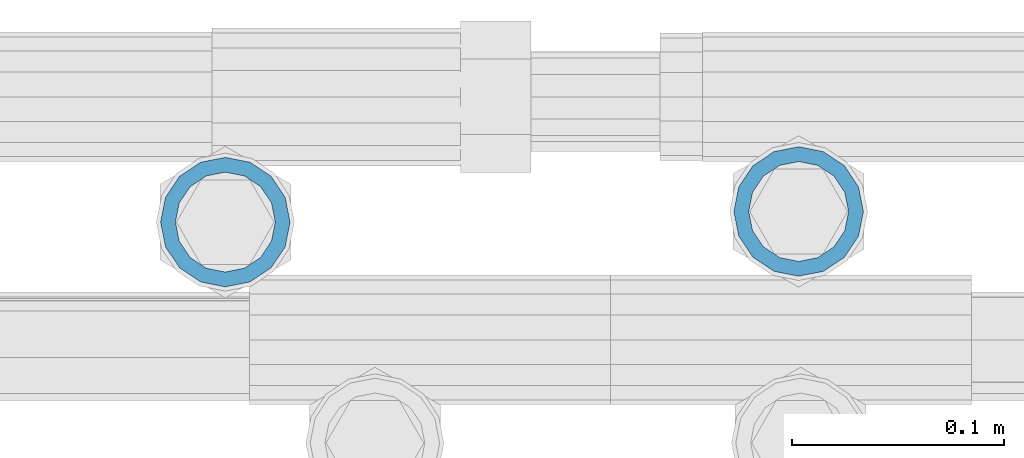
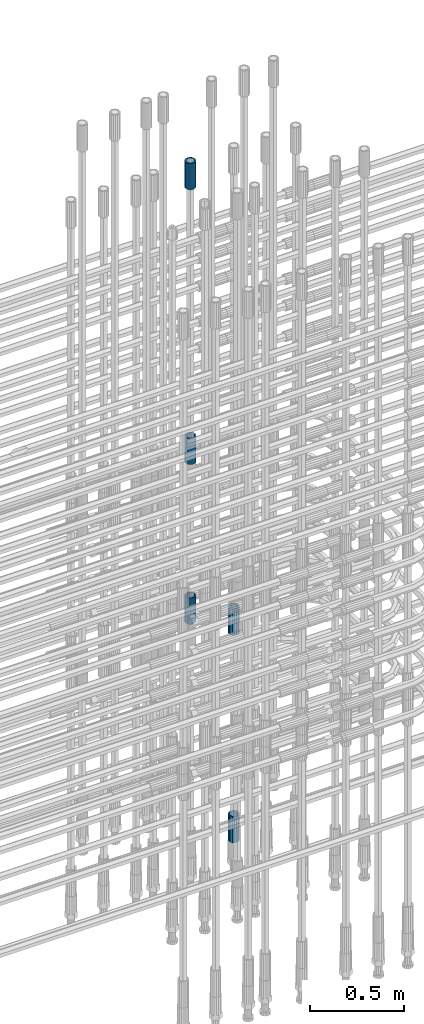
# One storey, part 75 of 119: 5 beams.
"""IFC2X3 building model written with IfcOpenShell, lengths in millimetres."""

from ifc_helpers import new_model, si_unit, frame, origin_with_axes, place, context, subcontext, project, spatial, faceted_brep, material, type_object, element, save


model = new_model("IFC2X3")

# Units and contexts
model_context = context("Model", 3, precision=1e-05, world=origin_with_axes())
body_context = subcontext(model_context, "Body", "Model", "MODEL_VIEW")
ifc_project = project(units=[si_unit("LENGTHUNIT", "METRE", prefix="MILLI"), si_unit("AREAUNIT", "SQUARE_METRE"), si_unit("VOLUMEUNIT", "CUBIC_METRE"), si_unit("MASSUNIT", "GRAM", prefix="KILO"), si_unit("TIMEUNIT", "SECOND"), si_unit("PLANEANGLEUNIT", "RADIAN"), si_unit("SOLIDANGLEUNIT", "STERADIAN"), si_unit("THERMODYNAMICTEMPERATUREUNIT", "DEGREE_CELSIUS"), si_unit("LUMINOUSINTENSITYUNIT", "LUMEN")], contexts=[model_context])

# Site, building, storey
site_placement = place(None, origin_with_axes())
site = spatial("IfcSite", under=ifc_project, at=site_placement, CompositionType="ELEMENT")
building_placement = place(site_placement, origin_with_axes())
building = spatial("IfcBuilding", under=site, at=building_placement, Name="Undefined", CompositionType="ELEMENT")
storey_placement = place(building_placement, origin_with_axes())
storey = spatial("IfcBuildingStorey", under=building, at=storey_placement, Name="Undefined", CompositionType="ELEMENT", Elevation=0.0)

# Beams
ifc_material = material(Name="STEEL/S275")
beam_type = type_object("IfcBeamType", PredefinedType="NOTDEFINED")
beam_1_placement = place(storey_placement, frame((2035854.99840131, 6206340.98567718, 20007.7168583146), z_axis=(-0.99999999999998, 1.98000110685822e-07, 0.0), x_axis=(0.0, 0.0, -1.0)))
element("IfcBeam", 1, at=beam_1_placement, inside=storey, type_object=beam_type, material=ifc_material, Name="AG40N", context=body_context, shape_type="Brep", body=[
    faceted_brep([(1.62981450557709e-09, -23.4999999990687, 0.0), (7.45058059692383e-09, -21.7111690142192, 8.99306066057534), (170.000002125278, -21.711168999318, 8.99306066022245), (170.000002127141, -23.4999999844003, -3.66071617463604e-10), (4.65661287307739e-09, -16.6170093587134, 16.6170093578889), (170.000002122484, -16.6170093440451, 16.6170093575288), (1.86264514923096e-09, -8.99306066217832, 21.7111690140277), (170.000002118759, -8.99306064750999, 21.7111690136603), (2.3283064365387e-10, 9.31322574615479e-10, 23.5), (170.000002114102, 1.28056854009628e-08, 23.4999999996485), (-6.51925802230835e-09, 8.99306065868586, 21.7111690140241), (170.00000211224, 8.99306067335419, 21.7111690136639), (-7.45058059692383e-09, 16.6170093561523, 16.6170093578853), (170.000002109446, 16.6170093708206, 16.6170093575324), (-9.31322574615479e-09, 21.711169013055, 8.99306066057534), (170.000002108514, 21.7111690277234, 8.99306066022245), (-1.16415321826935e-09, 23.5000000009313, 0.0), (170.000002108514, 23.5000000144355, -3.66071617463604e-10), (-8.38190317153931e-09, 21.7111690151505, -8.99306066059444), (170.000002110377, 21.7111690300517, -8.9930606609546), (-5.58793544769287e-09, 16.6170093598776, -16.6170093579008), (170.000002113171, 16.6170093745459, -16.6170093582609), (-9.31322574615479e-10, 8.99306066334248, -21.7111690140396), (170.000002115965, 8.99306067801081, -21.7111690143961), (2.3283064365387e-10, 9.31322574615479e-10, -23.5), (170.00000211969, 1.7927959561348e-08, -23.5000000003843), (5.58793544769287e-09, -8.99306065752171, -21.7111690140396), (170.000002123415, -8.99306064285338, -21.7111690143961), (8.38190317153931e-09, -16.6170093549881, -16.6170093579008), (170.000002125278, -16.6170093403198, -16.6170093582646), (9.31322574615479e-09, -21.7111690121237, -8.99306066059444), (170.000002127141, -21.7111689972226, -8.9930606609546), (1.11758708953857e-08, -30.4999999990687, -9.54969436861575e-12), (1.30385160446167e-08, -28.1783257392235, -11.6718446871514), (170.000002129003, -28.1783257243223, -11.6718446875116), (170.000002129935, -30.4999999841675, -3.66071617463604e-10), (1.02445483207703e-08, -21.5667568228673, -21.5667568262129), (170.000002128072, -21.566756808199, -21.5667568265694), (7.45058059692383e-09, -11.6718446831219, -28.1783257416196), (170.000002125278, -11.6718446684536, -28.1783257419834), (3.72529029846191e-09, 3.95812094211578e-09, -30.5000000000277), (170.00000211969, 1.83936208486557e-08, -30.5000000003879), (-9.31322574615479e-10, 11.6718446905725, -28.1783257416232), (170.000002115965, 11.6718447052408, -28.1783257419797), (-6.51925802230835e-09, 21.5667568286881, -21.5667568262093), (170.000002110377, 21.5667568433564, -21.5667568265694), (-9.31322574615479e-09, 28.178325742716, -11.6718446871478), (170.000002108514, 28.1783257573843, -11.6718446875079), (-1.21071934700012e-08, 30.5, -5.91171556152403e-12), (170.000002106652, 30.5000000144355, -3.62433638656512e-10), (-1.21071934700012e-08, 28.1783257401548, 11.6718446871359), (170.00000210572, 28.1783257548232, 11.6718446867794), (-1.02445483207703e-08, 21.5667568240315, 21.5667568261974), (170.000002107583, 21.566756838467, 21.5667568258409), (-7.45058059692383e-09, 11.671844684286, 28.1783257416041), (170.000002110377, 11.6718446989544, 28.178325741244), (-2.79396772384644e-09, -2.56113708019257e-09, 30.5000000000159), (170.000002114102, 1.18743628263474e-08, 30.4999999996558), (1.86264514923096e-09, -11.6718446896411, 28.1783257416114), (170.000002118759, -11.67184467474, 28.178325741244), (7.45058059692383e-09, -21.5667568275239, 21.5667568261974), (170.000002123415, -21.5667568126228, 21.5667568258373), (1.02445483207703e-08, -28.1783257415518, 11.6718446871359), (170.000002127141, -28.1783257271163, 11.6718446867794)], [[[0, 1, 2, 3]], [[1, 4, 5, 2]], [[4, 6, 7, 5]], [[6, 8, 9, 7]], [[8, 10, 11, 9]], [[10, 12, 13, 11]], [[12, 14, 15, 13]], [[14, 16, 17, 15]], [[16, 18, 19, 17]], [[18, 20, 21, 19]], [[20, 22, 23, 21]], [[22, 24, 25, 23]], [[24, 26, 27, 25]], [[26, 28, 29, 27]], [[28, 30, 31, 29]], [[30, 0, 3, 31]], [[32, 33, 34, 35]], [[33, 36, 37, 34]], [[36, 38, 39, 37]], [[38, 40, 41, 39]], [[40, 42, 43, 41]], [[42, 44, 45, 43]], [[44, 46, 47, 45]], [[46, 48, 49, 47]], [[48, 50, 51, 49]], [[50, 52, 53, 51]], [[52, 54, 55, 53]], [[54, 56, 57, 55]], [[56, 58, 59, 57]], [[58, 60, 61, 59]], [[60, 62, 63, 61]], [[62, 32, 35, 63]], [[37, 39, 41, 43, 45, 47, 49, 51, 53, 55, 57, 59, 61, 63, 35, 34], [5, 7, 9, 11, 13, 15, 17, 19, 21, 23, 25, 27, 29, 31, 3, 2]], [[62, 60, 58, 56, 54, 52, 50, 48, 46, 44, 42, 40, 38, 36, 33, 32], [30, 28, 26, 24, 22, 20, 18, 16, 14, 12, 10, 8, 6, 4, 1, 0]]]),
])
beam_2_placement = place(storey_placement, frame((2035854.99840131, 6206340.98567718, 22659.9857291637), z_axis=(1.0, 0.0, 0.0), x_axis=(0.0, 0.0, 1.0)))
element("IfcBeam", 2, at=beam_2_placement, inside=storey, type_object=beam_type, material=ifc_material, Name="AG40N", context=body_context, shape_type="Brep", body=[
    faceted_brep([(1.62981450557709e-09, -23.4999999990687, 0.0), (7.45058059692383e-09, -21.7111690142192, 8.99306066057534), (170.000002125278, -21.711168999318, 8.99306066022245), (170.000002127141, -23.4999999844003, -3.66071617463604e-10), (4.65661287307739e-09, -16.6170093587134, 16.6170093578889), (170.000002122484, -16.6170093440451, 16.6170093575288), (1.86264514923096e-09, -8.99306066217832, 21.7111690140277), (170.000002118759, -8.99306064750999, 21.7111690136603), (2.3283064365387e-10, 9.31322574615479e-10, 23.5), (170.000002114102, 1.28056854009628e-08, 23.4999999996485), (-6.51925802230835e-09, 8.99306065868586, 21.7111690140241), (170.00000211224, 8.99306067335419, 21.7111690136639), (-7.45058059692383e-09, 16.6170093561523, 16.6170093578853), (170.000002109446, 16.6170093708206, 16.6170093575324), (-9.31322574615479e-09, 21.711169013055, 8.99306066057534), (170.000002108514, 21.7111690277234, 8.99306066022245), (-1.16415321826935e-09, 23.5000000009313, 0.0), (170.000002108514, 23.5000000144355, -3.66071617463604e-10), (-8.38190317153931e-09, 21.7111690151505, -8.99306066059444), (170.000002110377, 21.7111690300517, -8.9930606609546), (-5.58793544769287e-09, 16.6170093598776, -16.6170093579008), (170.000002113171, 16.6170093745459, -16.6170093582609), (-9.31322574615479e-10, 8.99306066334248, -21.7111690140396), (170.000002115965, 8.99306067801081, -21.7111690143961), (2.3283064365387e-10, 9.31322574615479e-10, -23.5), (170.00000211969, 1.7927959561348e-08, -23.5000000003843), (5.58793544769287e-09, -8.99306065752171, -21.7111690140396), (170.000002123415, -8.99306064285338, -21.7111690143961), (8.38190317153931e-09, -16.6170093549881, -16.6170093579008), (170.000002125278, -16.6170093403198, -16.6170093582646), (9.31322574615479e-09, -21.7111690121237, -8.99306066059444), (170.000002127141, -21.7111689972226, -8.9930606609546), (1.11758708953857e-08, -30.4999999990687, -9.54969436861575e-12), (1.30385160446167e-08, -28.1783257392235, -11.6718446871514), (170.000002129003, -28.1783257243223, -11.6718446875116), (170.000002129935, -30.4999999841675, -3.66071617463604e-10), (1.02445483207703e-08, -21.5667568228673, -21.5667568262129), (170.000002128072, -21.566756808199, -21.5667568265694), (7.45058059692383e-09, -11.6718446831219, -28.1783257416196), (170.000002125278, -11.6718446684536, -28.1783257419834), (3.72529029846191e-09, 3.95812094211578e-09, -30.5000000000277), (170.00000211969, 1.83936208486557e-08, -30.5000000003879), (-9.31322574615479e-10, 11.6718446905725, -28.1783257416232), (170.000002115965, 11.6718447052408, -28.1783257419797), (-6.51925802230835e-09, 21.5667568286881, -21.5667568262093), (170.000002110377, 21.5667568433564, -21.5667568265694), (-9.31322574615479e-09, 28.178325742716, -11.6718446871478), (170.000002108514, 28.1783257573843, -11.6718446875079), (-1.21071934700012e-08, 30.5, -5.91171556152403e-12), (170.000002106652, 30.5000000144355, -3.62433638656512e-10), (-1.21071934700012e-08, 28.1783257401548, 11.6718446871359), (170.00000210572, 28.1783257548232, 11.6718446867794), (-1.02445483207703e-08, 21.5667568240315, 21.5667568261974), (170.000002107583, 21.566756838467, 21.5667568258409), (-7.45058059692383e-09, 11.671844684286, 28.1783257416041), (170.000002110377, 11.6718446989544, 28.178325741244), (-2.79396772384644e-09, -2.56113708019257e-09, 30.5000000000159), (170.000002114102, 1.18743628263474e-08, 30.4999999996558), (1.86264514923096e-09, -11.6718446896411, 28.1783257416114), (170.000002118759, -11.67184467474, 28.178325741244), (7.45058059692383e-09, -21.5667568275239, 21.5667568261974), (170.000002123415, -21.5667568126228, 21.5667568258373), (1.02445483207703e-08, -28.1783257415518, 11.6718446871359), (170.000002127141, -28.1783257271163, 11.6718446867794)], [[[0, 1, 2, 3]], [[1, 4, 5, 2]], [[4, 6, 7, 5]], [[6, 8, 9, 7]], [[8, 10, 11, 9]], [[10, 12, 13, 11]], [[12, 14, 15, 13]], [[14, 16, 17, 15]], [[16, 18, 19, 17]], [[18, 20, 21, 19]], [[20, 22, 23, 21]], [[22, 24, 25, 23]], [[24, 26, 27, 25]], [[26, 28, 29, 27]], [[28, 30, 31, 29]], [[30, 0, 3, 31]], [[32, 33, 34, 35]], [[33, 36, 37, 34]], [[36, 38, 39, 37]], [[38, 40, 41, 39]], [[40, 42, 43, 41]], [[42, 44, 45, 43]], [[44, 46, 47, 45]], [[46, 48, 49, 47]], [[48, 50, 51, 49]], [[50, 52, 53, 51]], [[52, 54, 55, 53]], [[54, 56, 57, 55]], [[56, 58, 59, 57]], [[58, 60, 61, 59]], [[60, 62, 63, 61]], [[62, 32, 35, 63]], [[37, 39, 41, 43, 45, 47, 49, 51, 53, 55, 57, 59, 61, 63, 35, 34], [5, 7, 9, 11, 13, 15, 17, 19, 21, 23, 25, 27, 29, 31, 3, 2]], [[62, 60, 58, 56, 54, 52, 50, 48, 46, 44, 42, 40, 38, 36, 33, 32], [30, 28, 26, 24, 22, 20, 18, 16, 14, 12, 10, 8, 6, 4, 1, 0]]]),
])
beam_3_placement = place(storey_placement, frame((2035854.99840131, 6206340.98567718, 21044.6068583139), z_axis=(-0.99999999999998, 1.98000110685822e-07, 0.0), x_axis=(0.0, 0.0, -1.0)))
element("IfcBeam", 3, at=beam_3_placement, inside=storey, type_object=beam_type, material=ifc_material, Name="AG40N", context=body_context, shape_type="Brep", body=[
    faceted_brep([(1.62981450557709e-09, -23.4999999990687, 0.0), (7.45058059692383e-09, -21.7111690142192, 8.99306066057534), (170.000002125278, -21.711168999318, 8.99306066022245), (170.000002127141, -23.4999999844003, -3.66071617463604e-10), (4.65661287307739e-09, -16.6170093587134, 16.6170093578889), (170.000002122484, -16.6170093440451, 16.6170093575288), (1.86264514923096e-09, -8.99306066217832, 21.7111690140277), (170.000002118759, -8.99306064750999, 21.7111690136603), (2.3283064365387e-10, 9.31322574615479e-10, 23.5), (170.000002114102, 1.28056854009628e-08, 23.4999999996485), (-6.51925802230835e-09, 8.99306065868586, 21.7111690140241), (170.00000211224, 8.99306067335419, 21.7111690136639), (-7.45058059692383e-09, 16.6170093561523, 16.6170093578853), (170.000002109446, 16.6170093708206, 16.6170093575324), (-9.31322574615479e-09, 21.711169013055, 8.99306066057534), (170.000002108514, 21.7111690277234, 8.99306066022245), (-1.16415321826935e-09, 23.5000000009313, 0.0), (170.000002108514, 23.5000000144355, -3.66071617463604e-10), (-8.38190317153931e-09, 21.7111690151505, -8.99306066059444), (170.000002110377, 21.7111690300517, -8.9930606609546), (-5.58793544769287e-09, 16.6170093598776, -16.6170093579008), (170.000002113171, 16.6170093745459, -16.6170093582609), (-9.31322574615479e-10, 8.99306066334248, -21.7111690140396), (170.000002115965, 8.99306067801081, -21.7111690143961), (2.3283064365387e-10, 9.31322574615479e-10, -23.5), (170.00000211969, 1.7927959561348e-08, -23.5000000003843), (5.58793544769287e-09, -8.99306065752171, -21.7111690140396), (170.000002123415, -8.99306064285338, -21.7111690143961), (8.38190317153931e-09, -16.6170093549881, -16.6170093579008), (170.000002125278, -16.6170093403198, -16.6170093582646), (9.31322574615479e-09, -21.7111690121237, -8.99306066059444), (170.000002127141, -21.7111689972226, -8.9930606609546), (1.11758708953857e-08, -30.4999999990687, -9.54969436861575e-12), (1.30385160446167e-08, -28.1783257392235, -11.6718446871514), (170.000002129003, -28.1783257243223, -11.6718446875116), (170.000002129935, -30.4999999841675, -3.66071617463604e-10), (1.02445483207703e-08, -21.5667568228673, -21.5667568262129), (170.000002128072, -21.566756808199, -21.5667568265694), (7.45058059692383e-09, -11.6718446831219, -28.1783257416196), (170.000002125278, -11.6718446684536, -28.1783257419834), (3.72529029846191e-09, 3.95812094211578e-09, -30.5000000000277), (170.00000211969, 1.83936208486557e-08, -30.5000000003879), (-9.31322574615479e-10, 11.6718446905725, -28.1783257416232), (170.000002115965, 11.6718447052408, -28.1783257419797), (-6.51925802230835e-09, 21.5667568286881, -21.5667568262093), (170.000002110377, 21.5667568433564, -21.5667568265694), (-9.31322574615479e-09, 28.178325742716, -11.6718446871478), (170.000002108514, 28.1783257573843, -11.6718446875079), (-1.21071934700012e-08, 30.5, -5.91171556152403e-12), (170.000002106652, 30.5000000144355, -3.62433638656512e-10), (-1.21071934700012e-08, 28.1783257401548, 11.6718446871359), (170.00000210572, 28.1783257548232, 11.6718446867794), (-1.02445483207703e-08, 21.5667568240315, 21.5667568261974), (170.000002107583, 21.566756838467, 21.5667568258409), (-7.45058059692383e-09, 11.671844684286, 28.1783257416041), (170.000002110377, 11.6718446989544, 28.178325741244), (-2.79396772384644e-09, -2.56113708019257e-09, 30.5000000000159), (170.000002114102, 1.18743628263474e-08, 30.4999999996558), (1.86264514923096e-09, -11.6718446896411, 28.1783257416114), (170.000002118759, -11.67184467474, 28.178325741244), (7.45058059692383e-09, -21.5667568275239, 21.5667568261974), (170.000002123415, -21.5667568126228, 21.5667568258373), (1.02445483207703e-08, -28.1783257415518, 11.6718446871359), (170.000002127141, -28.1783257271163, 11.6718446867794)], [[[0, 1, 2, 3]], [[1, 4, 5, 2]], [[4, 6, 7, 5]], [[6, 8, 9, 7]], [[8, 10, 11, 9]], [[10, 12, 13, 11]], [[12, 14, 15, 13]], [[14, 16, 17, 15]], [[16, 18, 19, 17]], [[18, 20, 21, 19]], [[20, 22, 23, 21]], [[22, 24, 25, 23]], [[24, 26, 27, 25]], [[26, 28, 29, 27]], [[28, 30, 31, 29]], [[30, 0, 3, 31]], [[32, 33, 34, 35]], [[33, 36, 37, 34]], [[36, 38, 39, 37]], [[38, 40, 41, 39]], [[40, 42, 43, 41]], [[42, 44, 45, 43]], [[44, 46, 47, 45]], [[46, 48, 49, 47]], [[48, 50, 51, 49]], [[50, 52, 53, 51]], [[52, 54, 55, 53]], [[54, 56, 57, 55]], [[56, 58, 59, 57]], [[58, 60, 61, 59]], [[60, 62, 63, 61]], [[62, 32, 35, 63]], [[37, 39, 41, 43, 45, 47, 49, 51, 53, 55, 57, 59, 61, 63, 35, 34], [5, 7, 9, 11, 13, 15, 17, 19, 21, 23, 25, 27, 29, 31, 3, 2]], [[62, 60, 58, 56, 54, 52, 50, 48, 46, 44, 42, 40, 38, 36, 33, 32], [30, 28, 26, 24, 22, 20, 18, 16, 14, 12, 10, 8, 6, 4, 1, 0]]]),
])
beam_4_placement = place(storey_placement, frame((2036124.99838223, 6206345.98579162, 19667.7157291644), z_axis=(1.0, 0.0, 0.0), x_axis=(0.0, 0.0, 1.0)))
element("IfcBeam", 4, at=beam_4_placement, inside=storey, type_object=beam_type, material=ifc_material, Name="AG40N", context=body_context, shape_type="Brep", body=[
    faceted_brep([(1.62981450557709e-09, -23.4999999990687, 0.0), (7.45058059692383e-09, -21.7111690142192, 8.99306066057534), (170.000002125278, -21.711168999318, 8.99306066022245), (170.000002127141, -23.4999999844003, -3.66071617463604e-10), (4.65661287307739e-09, -16.6170093587134, 16.6170093578889), (170.000002122484, -16.6170093440451, 16.6170093575288), (1.86264514923096e-09, -8.99306066217832, 21.7111690140277), (170.000002118759, -8.99306064750999, 21.7111690136603), (2.3283064365387e-10, 9.31322574615479e-10, 23.5), (170.000002114102, 1.28056854009628e-08, 23.4999999996485), (-6.51925802230835e-09, 8.99306065868586, 21.7111690140241), (170.00000211224, 8.99306067335419, 21.7111690136639), (-7.45058059692383e-09, 16.6170093561523, 16.6170093578853), (170.000002109446, 16.6170093708206, 16.6170093575324), (-9.31322574615479e-09, 21.711169013055, 8.99306066057534), (170.000002108514, 21.7111690277234, 8.99306066022245), (-1.16415321826935e-09, 23.5000000009313, 0.0), (170.000002108514, 23.5000000144355, -3.66071617463604e-10), (-8.38190317153931e-09, 21.7111690151505, -8.99306066059444), (170.000002110377, 21.7111690300517, -8.9930606609546), (-5.58793544769287e-09, 16.6170093598776, -16.6170093579008), (170.000002113171, 16.6170093745459, -16.6170093582609), (-9.31322574615479e-10, 8.99306066334248, -21.7111690140396), (170.000002115965, 8.99306067801081, -21.7111690143961), (2.3283064365387e-10, 9.31322574615479e-10, -23.5), (170.00000211969, 1.7927959561348e-08, -23.5000000003843), (5.58793544769287e-09, -8.99306065752171, -21.7111690140396), (170.000002123415, -8.99306064285338, -21.7111690143961), (8.38190317153931e-09, -16.6170093549881, -16.6170093579008), (170.000002125278, -16.6170093403198, -16.6170093582646), (9.31322574615479e-09, -21.7111690121237, -8.99306066059444), (170.000002127141, -21.7111689972226, -8.9930606609546), (1.11758708953857e-08, -30.4999999990687, -9.54969436861575e-12), (1.30385160446167e-08, -28.1783257392235, -11.6718446871514), (170.000002129003, -28.1783257243223, -11.6718446875116), (170.000002129935, -30.4999999841675, -3.66071617463604e-10), (1.02445483207703e-08, -21.5667568228673, -21.5667568262129), (170.000002128072, -21.566756808199, -21.5667568265694), (7.45058059692383e-09, -11.6718446831219, -28.1783257416196), (170.000002125278, -11.6718446684536, -28.1783257419834), (3.72529029846191e-09, 3.95812094211578e-09, -30.5000000000277), (170.00000211969, 1.83936208486557e-08, -30.5000000003879), (-9.31322574615479e-10, 11.6718446905725, -28.1783257416232), (170.000002115965, 11.6718447052408, -28.1783257419797), (-6.51925802230835e-09, 21.5667568286881, -21.5667568262093), (170.000002110377, 21.5667568433564, -21.5667568265694), (-9.31322574615479e-09, 28.178325742716, -11.6718446871478), (170.000002108514, 28.1783257573843, -11.6718446875079), (-1.21071934700012e-08, 30.5, -5.91171556152403e-12), (170.000002106652, 30.5000000144355, -3.62433638656512e-10), (-1.21071934700012e-08, 28.1783257401548, 11.6718446871359), (170.00000210572, 28.1783257548232, 11.6718446867794), (-1.02445483207703e-08, 21.5667568240315, 21.5667568261974), (170.000002107583, 21.566756838467, 21.5667568258409), (-7.45058059692383e-09, 11.671844684286, 28.1783257416041), (170.000002110377, 11.6718446989544, 28.178325741244), (-2.79396772384644e-09, -2.56113708019257e-09, 30.5000000000159), (170.000002114102, 1.18743628263474e-08, 30.4999999996558), (1.86264514923096e-09, -11.6718446896411, 28.1783257416114), (170.000002118759, -11.67184467474, 28.178325741244), (7.45058059692383e-09, -21.5667568275239, 21.5667568261974), (170.000002123415, -21.5667568126228, 21.5667568258373), (1.02445483207703e-08, -28.1783257415518, 11.6718446871359), (170.000002127141, -28.1783257271163, 11.6718446867794)], [[[0, 1, 2, 3]], [[1, 4, 5, 2]], [[4, 6, 7, 5]], [[6, 8, 9, 7]], [[8, 10, 11, 9]], [[10, 12, 13, 11]], [[12, 14, 15, 13]], [[14, 16, 17, 15]], [[16, 18, 19, 17]], [[18, 20, 21, 19]], [[20, 22, 23, 21]], [[22, 24, 25, 23]], [[24, 26, 27, 25]], [[26, 28, 29, 27]], [[28, 30, 31, 29]], [[30, 0, 3, 31]], [[32, 33, 34, 35]], [[33, 36, 37, 34]], [[36, 38, 39, 37]], [[38, 40, 41, 39]], [[40, 42, 43, 41]], [[42, 44, 45, 43]], [[44, 46, 47, 45]], [[46, 48, 49, 47]], [[48, 50, 51, 49]], [[50, 52, 53, 51]], [[52, 54, 55, 53]], [[54, 56, 57, 55]], [[56, 58, 59, 57]], [[58, 60, 61, 59]], [[60, 62, 63, 61]], [[62, 32, 35, 63]], [[37, 39, 41, 43, 45, 47, 49, 51, 53, 55, 57, 59, 61, 63, 35, 34], [5, 7, 9, 11, 13, 15, 17, 19, 21, 23, 25, 27, 29, 31, 3, 2]], [[62, 60, 58, 56, 54, 52, 50, 48, 46, 44, 42, 40, 38, 36, 33, 32], [30, 28, 26, 24, 22, 20, 18, 16, 14, 12, 10, 8, 6, 4, 1, 0]]]),
])
beam_5_placement = place(storey_placement, frame((2036124.99838223, 6206345.98579162, 18490.9668583153), z_axis=(-0.99999999999998, 1.98000110685822e-07, 0.0), x_axis=(0.0, 0.0, -1.0)))
element("IfcBeam", 5, at=beam_5_placement, inside=storey, type_object=beam_type, material=ifc_material, Name="AG40N", context=body_context, shape_type="Brep", body=[
    faceted_brep([(1.62981450557709e-09, -23.4999999990687, 0.0), (7.45058059692383e-09, -21.7111690142192, 8.99306066057534), (170.000002125278, -21.711168999318, 8.99306066022245), (170.000002127141, -23.4999999844003, -3.66071617463604e-10), (4.65661287307739e-09, -16.6170093587134, 16.6170093578889), (170.000002122484, -16.6170093440451, 16.6170093575288), (1.86264514923096e-09, -8.99306066217832, 21.7111690140277), (170.000002118759, -8.99306064750999, 21.7111690136603), (2.3283064365387e-10, 9.31322574615479e-10, 23.5), (170.000002114102, 1.28056854009628e-08, 23.4999999996485), (-6.51925802230835e-09, 8.99306065868586, 21.7111690140241), (170.00000211224, 8.99306067335419, 21.7111690136639), (-7.45058059692383e-09, 16.6170093561523, 16.6170093578853), (170.000002109446, 16.6170093708206, 16.6170093575324), (-9.31322574615479e-09, 21.711169013055, 8.99306066057534), (170.000002108514, 21.7111690277234, 8.99306066022245), (-1.16415321826935e-09, 23.5000000009313, 0.0), (170.000002108514, 23.5000000144355, -3.66071617463604e-10), (-8.38190317153931e-09, 21.7111690151505, -8.99306066059444), (170.000002110377, 21.7111690300517, -8.9930606609546), (-5.58793544769287e-09, 16.6170093598776, -16.6170093579008), (170.000002113171, 16.6170093745459, -16.6170093582609), (-9.31322574615479e-10, 8.99306066334248, -21.7111690140396), (170.000002115965, 8.99306067801081, -21.7111690143961), (2.3283064365387e-10, 9.31322574615479e-10, -23.5), (170.00000211969, 1.7927959561348e-08, -23.5000000003843), (5.58793544769287e-09, -8.99306065752171, -21.7111690140396), (170.000002123415, -8.99306064285338, -21.7111690143961), (8.38190317153931e-09, -16.6170093549881, -16.6170093579008), (170.000002125278, -16.6170093403198, -16.6170093582646), (9.31322574615479e-09, -21.7111690121237, -8.99306066059444), (170.000002127141, -21.7111689972226, -8.9930606609546), (1.11758708953857e-08, -30.4999999990687, -9.54969436861575e-12), (1.30385160446167e-08, -28.1783257392235, -11.6718446871514), (170.000002129003, -28.1783257243223, -11.6718446875116), (170.000002129935, -30.4999999841675, -3.66071617463604e-10), (1.02445483207703e-08, -21.5667568228673, -21.5667568262129), (170.000002128072, -21.566756808199, -21.5667568265694), (7.45058059692383e-09, -11.6718446831219, -28.1783257416196), (170.000002125278, -11.6718446684536, -28.1783257419834), (3.72529029846191e-09, 3.95812094211578e-09, -30.5000000000277), (170.00000211969, 1.83936208486557e-08, -30.5000000003879), (-9.31322574615479e-10, 11.6718446905725, -28.1783257416232), (170.000002115965, 11.6718447052408, -28.1783257419797), (-6.51925802230835e-09, 21.5667568286881, -21.5667568262093), (170.000002110377, 21.5667568433564, -21.5667568265694), (-9.31322574615479e-09, 28.178325742716, -11.6718446871478), (170.000002108514, 28.1783257573843, -11.6718446875079), (-1.21071934700012e-08, 30.5, -5.91171556152403e-12), (170.000002106652, 30.5000000144355, -3.62433638656512e-10), (-1.21071934700012e-08, 28.1783257401548, 11.6718446871359), (170.00000210572, 28.1783257548232, 11.6718446867794), (-1.02445483207703e-08, 21.5667568240315, 21.5667568261974), (170.000002107583, 21.566756838467, 21.5667568258409), (-7.45058059692383e-09, 11.671844684286, 28.1783257416041), (170.000002110377, 11.6718446989544, 28.178325741244), (-2.79396772384644e-09, -2.56113708019257e-09, 30.5000000000159), (170.000002114102, 1.18743628263474e-08, 30.4999999996558), (1.86264514923096e-09, -11.6718446896411, 28.1783257416114), (170.000002118759, -11.67184467474, 28.178325741244), (7.45058059692383e-09, -21.5667568275239, 21.5667568261974), (170.000002123415, -21.5667568126228, 21.5667568258373), (1.02445483207703e-08, -28.1783257415518, 11.6718446871359), (170.000002127141, -28.1783257271163, 11.6718446867794)], [[[0, 1, 2, 3]], [[1, 4, 5, 2]], [[4, 6, 7, 5]], [[6, 8, 9, 7]], [[8, 10, 11, 9]], [[10, 12, 13, 11]], [[12, 14, 15, 13]], [[14, 16, 17, 15]], [[16, 18, 19, 17]], [[18, 20, 21, 19]], [[20, 22, 23, 21]], [[22, 24, 25, 23]], [[24, 26, 27, 25]], [[26, 28, 29, 27]], [[28, 30, 31, 29]], [[30, 0, 3, 31]], [[32, 33, 34, 35]], [[33, 36, 37, 34]], [[36, 38, 39, 37]], [[38, 40, 41, 39]], [[40, 42, 43, 41]], [[42, 44, 45, 43]], [[44, 46, 47, 45]], [[46, 48, 49, 47]], [[48, 50, 51, 49]], [[50, 52, 53, 51]], [[52, 54, 55, 53]], [[54, 56, 57, 55]], [[56, 58, 59, 57]], [[58, 60, 61, 59]], [[60, 62, 63, 61]], [[62, 32, 35, 63]], [[37, 39, 41, 43, 45, 47, 49, 51, 53, 55, 57, 59, 61, 63, 35, 34], [5, 7, 9, 11, 13, 15, 17, 19, 21, 23, 25, 27, 29, 31, 3, 2]], [[62, 60, 58, 56, 54, 52, 50, 48, 46, 44, 42, 40, 38, 36, 33, 32], [30, 28, 26, 24, 22, 20, 18, 16, 14, 12, 10, 8, 6, 4, 1, 0]]]),
])

save(model, "model.ifc")
